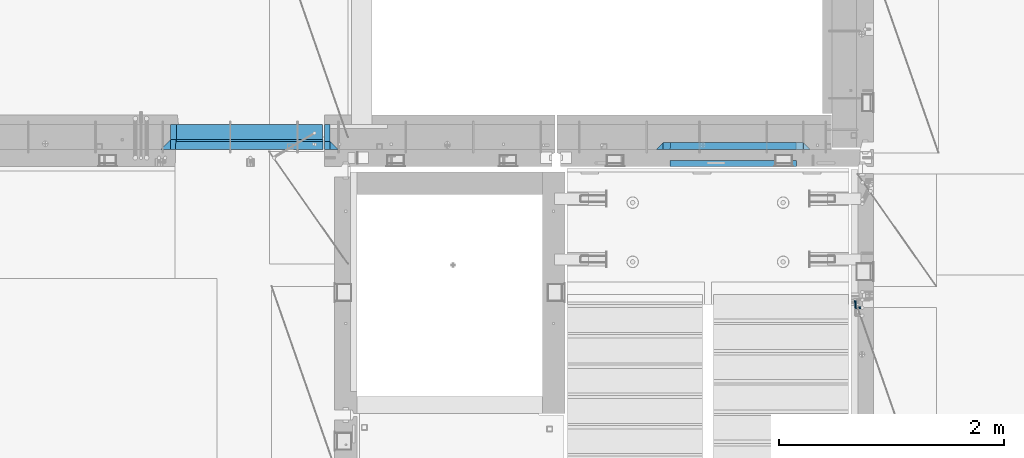
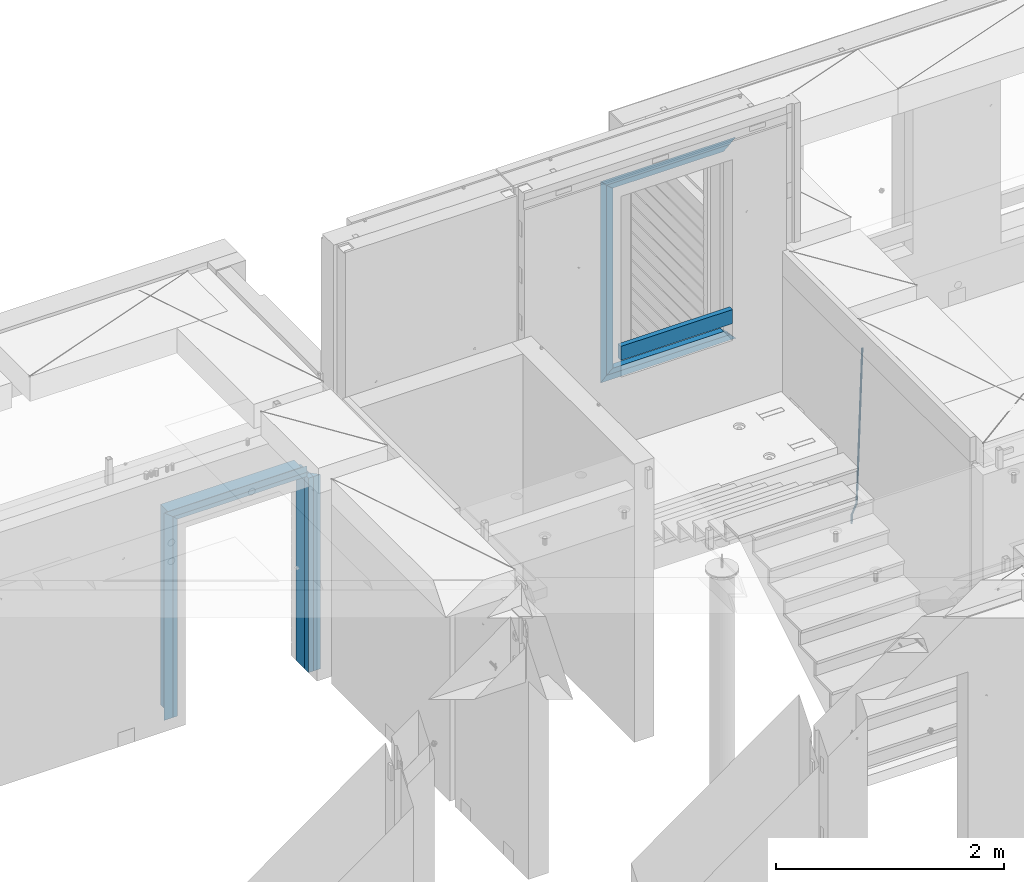
# One storey, part 105 of 325: 17 beams, 4 elements without a shape of their own.
"""IFC2X3 building model written with IfcOpenShell, lengths in millimetres."""

import ifcopenshell
import ifcopenshell.guid

model = None  # the IFC model being written
_history = None  # IfcOwnerHistory: only IFC2X3 demands one
_inside = {}  # id of a spatial element -> (the spatial element, [elements in it])
_under = {}  # id of a project, library or spatial element -> (it, [spatial elements below it])
_declared = {}  # id of a project -> (the project, [libraries it declares])
_typed = {}  # id of a type object -> (the type object, [elements of that type])
_made_of = {}  # id of a material, layer set ... -> (it, [elements and type objects made of it])


def new_model(schema):
    """Start an empty IFC model of exactly this schema.

    Asked for "IFC4X3", IfcOpenShell would pick the latest addendum, in which some entities
    have other attributes; the version numbers below select the first issue.
    IFC2X3 requires an IfcOwnerHistory on every rooted entity: one is made here for all.
    """
    global model, _history
    if schema == "IFC4X3":
        model = ifcopenshell.file(schema_version=(4, 3, 0, 0))
    else:
        model = ifcopenshell.file(schema=schema)
    _inside.clear()
    _under.clear()
    _declared.clear()
    _typed.clear()
    _made_of.clear()
    _history = None
    if model.schema == "IFC2X3":
        org = make("IfcOrganization", Name="unknown")
        user = make(
            "IfcPersonAndOrganization",
            ThePerson=make("IfcPerson", FamilyName="unknown"),
            TheOrganization=org,
        )
        app = make(
            "IfcApplication",
            ApplicationDeveloper=org,
            Version="unknown",
            ApplicationFullName="unknown",
            ApplicationIdentifier="unknown",
        )
        _history = make(
            "IfcOwnerHistory",
            OwningUser=user,
            OwningApplication=app,
            ChangeAction="ADDED",
            CreationDate=0,
        )
    return model


def make(cls, **values):
    """One entity of the class cls with the attributes given. An attribute that is None is left unset."""
    return model.create_entity(
        cls, **{name: value for name, value in values.items() if value is not None}
    )


def rooted(cls, **values):
    """An entity with a GlobalId (a new one), such as an element, a storey or a relation."""
    return make(cls, GlobalId=ifcopenshell.guid.new(), OwnerHistory=_history, **values)


def si_unit(unit_type, name, prefix=None):
    """IfcSIUnit, for example si_unit("LENGTHUNIT", "METRE", prefix="MILLI")."""
    return make("IfcSIUnit", UnitType=unit_type, Prefix=prefix, Name=name)


def assignment(units):
    """IfcUnitAssignment: the units of a project."""
    return None if units is None else make("IfcUnitAssignment", Units=units)


def point(xyz):
    """IfcCartesianPoint."""
    return None if xyz is None else make("IfcCartesianPoint", Coordinates=xyz)


def direction(xyz):
    """IfcDirection."""
    return None if xyz is None else make("IfcDirection", DirectionRatios=xyz)


def frame(location, z_axis=None, x_axis=None):
    """IfcAxis2Placement3D, a coordinate frame: its origin and axes. An axis left out is left unset."""
    return make(
        "IfcAxis2Placement3D",
        Location=point(location),
        Axis=direction(z_axis),
        RefDirection=direction(x_axis),
    )


def origin_with_axes():
    """The frame at (0, 0, 0) with the z axis (0, 0, 1) and the x axis (1, 0, 0) written out."""
    return frame((0.0, 0.0, 0.0), z_axis=(0.0, 0.0, 1.0), x_axis=(1.0, 0.0, 0.0))


def place(relative_to, where):
    """IfcLocalPlacement: puts the frame where relative to a parent placement (None: the world)."""
    return make(
        "IfcLocalPlacement", PlacementRelTo=relative_to, RelativePlacement=where
    )


def context(
    kind, dimensions, precision=None, world=None, true_north=None, identifier=None
):
    """IfcGeometricRepresentationContext, for example the 3D "Model" context."""
    return make(
        "IfcGeometricRepresentationContext",
        ContextIdentifier=identifier,
        ContextType=kind,
        CoordinateSpaceDimension=dimensions,
        Precision=precision,
        WorldCoordinateSystem=world,
        TrueNorth=true_north,
    )


def subcontext(parent, identifier, kind, view, scale=None):
    """IfcGeometricRepresentationSubContext, for example "Body" below "Model"."""
    return make(
        "IfcGeometricRepresentationSubContext",
        ContextIdentifier=identifier,
        ContextType=kind,
        ParentContext=parent,
        TargetScale=scale,
        TargetView=view,
    )


def project(units=None, contexts=None):
    """IfcProject with its units and contexts."""
    return rooted(
        "IfcProject",
        Name="project",
        RepresentationContexts=contexts,
        UnitsInContext=assignment(units),
    )


def spatial(cls, under=None, at=None, **own):
    """A site, building, storey or space (cls), placed at a placement, below another one or the project."""
    s = rooted(cls, ObjectPlacement=at, **own)
    if under is not None:
        _under.setdefault(under.id(), (under, []))[1].append(s)
    return s


def faces_of(points, faces, orient=None, outer=None):
    """IfcFace entities. A face is a list of loops; a loop is a list of indices into points, from 0.

    orient and outer hold one flag for each loop. By default every Orientation is true, the
    first loop of a face is its IfcFaceOuterBound and the others are IfcFaceBound.
    """
    made = []
    for i, loops in enumerate(faces):
        bounds = []
        for j, loop in enumerate(loops):
            is_outer = j == 0 if outer is None else outer[i][j]
            bounds.append(
                make(
                    "IfcFaceOuterBound" if is_outer else "IfcFaceBound",
                    Bound=make("IfcPolyLoop", Polygon=[points[k] for k in loop]),
                    Orientation=True if orient is None else orient[i][j],
                )
            )
        made.append(make("IfcFace", Bounds=bounds))
    return made


def faceted_brep(points, faces, orient=None, outer=None, voids=None):
    """IfcFacetedBrep: a solid bounded by flat faces; with voids (closed shells), ...WithVoids."""
    shared = [point(p) for p in points]
    hull = make("IfcClosedShell", CfsFaces=faces_of(shared, faces, orient, outer))
    if voids is None:
        return make("IfcFacetedBrep", Outer=hull)
    return make(
        "IfcFacetedBrepWithVoids",
        Outer=hull,
        Voids=[
            make(cls, CfsFaces=faces_of(shared, fs, o, b)) for cls, fs, o, b in voids
        ],
    )


def shape(context_of_items, identifier, shape_type, items):
    """IfcShapeRepresentation: the items that make up one representation, for example the "Body"."""
    return make(
        "IfcShapeRepresentation",
        ContextOfItems=context_of_items,
        RepresentationIdentifier=identifier,
        RepresentationType=shape_type,
        Items=items,
    )


def material(Name=None, Category=None):
    """IfcMaterial."""
    return make("IfcMaterial", Name=Name, Category=Category)


def made_of(thing, what):
    """Note that an element or type object is made of a material, layer set ...; save() writes the relation."""
    if what is not None:
        _made_of.setdefault(what.id(), (what, []))[1].append(thing)
    return thing


def type_object(cls, material=None, **own):
    """A type object (cls), such as IfcWallType, which elements share."""
    return made_of(rooted(cls, **own), material)


def element(
    cls,
    number,
    at=None,
    inside=None,
    cuts=None,
    type_object=None,
    material=None,
    context=None,
    identifier="Body",
    shape_type=None,
    held_by="IfcProductDefinitionShape",
    body=None,
    shapes=None,
    **own,
):
    """One element of the class cls, such as IfcWall. Its Tag is "e" and its number.

    at: its placement. inside: the storey or other place that contains it. cuts: it is an
    opening in that element (IfcRelVoidsElement). A single representation is given by context,
    identifier, shape_type and body (its items); several are given by shapes. held_by: the class
    of the entity that holds the representations. save() writes the other relations.
    """
    e = rooted(cls, Tag="e%d" % number, ObjectPlacement=at, **own)
    if body is not None:
        shapes = [shape(context, identifier, shape_type, body)]
    if shapes is not None:
        e.Representation = make(held_by, Representations=shapes)
    if inside is not None:
        _inside.setdefault(inside.id(), (inside, []))[1].append(e)
    if cuts is not None:
        rooted(
            "IfcRelVoidsElement", RelatingBuildingElement=cuts, RelatedOpeningElement=e
        )
    if type_object is not None:
        _typed.setdefault(type_object.id(), (type_object, []))[1].append(e)
    return made_of(e, material)


def aggregate(whole, parts):
    """IfcRelAggregates: a whole, such as a stair, and the parts it consists of."""
    return rooted("IfcRelAggregates", RelatingObject=whole, RelatedObjects=parts)


def save(model, path):
    """Write the relations noted so far, then the file.

    IfcRelAggregates (storeys below a building ...), IfcRelContainedInSpatialStructure (elements
    in a storey), IfcRelDefinesByType, IfcRelAssociatesMaterial and IfcRelDeclares: one each for
    every whole, place, type object, material and project.
    """
    for whole, parts in _under.values():
        aggregate(whole, parts)
    for where, things in _inside.values():
        rooted(
            "IfcRelContainedInSpatialStructure",
            RelatedElements=things,
            RelatingStructure=where,
        )
    for kind, things in _typed.values():
        rooted("IfcRelDefinesByType", RelatedObjects=things, RelatingType=kind)
    for what, things in _made_of.values():
        rooted("IfcRelAssociatesMaterial", RelatedObjects=things, RelatingMaterial=what)
    for by, libraries in _declared.values():
        rooted("IfcRelDeclares", RelatingContext=by, RelatedDefinitions=libraries)
    model.write(path)


model = new_model("IFC2X3")

# Units and contexts
model_context = context("Model", 3, precision=1e-05, world=origin_with_axes())
body_context = subcontext(model_context, "Body", "Model", "MODEL_VIEW")
ifc_project = project(units=[si_unit("LENGTHUNIT", "METRE", prefix="MILLI"), si_unit("AREAUNIT", "SQUARE_METRE"), si_unit("VOLUMEUNIT", "CUBIC_METRE"), si_unit("MASSUNIT", "GRAM", prefix="KILO"), si_unit("TIMEUNIT", "SECOND"), si_unit("PLANEANGLEUNIT", "RADIAN"), si_unit("SOLIDANGLEUNIT", "STERADIAN"), si_unit("THERMODYNAMICTEMPERATUREUNIT", "DEGREE_CELSIUS"), si_unit("LUMINOUSINTENSITYUNIT", "LUMEN")], contexts=[model_context])

# Site, building, storey
site_placement = place(None, origin_with_axes())
site = spatial("IfcSite", under=ifc_project, at=site_placement, CompositionType="ELEMENT")
building_placement = place(site_placement, origin_with_axes())
building = spatial("IfcBuilding", under=site, at=building_placement, CompositionType="ELEMENT")
storey_placement = place(building_placement, origin_with_axes())
storey = spatial("IfcBuildingStorey", under=building, at=storey_placement, Name="1", CompositionType="ELEMENT", Elevation=0.0)

# Assembly, beams
assembly_1_placement = place(storey_placement, origin_with_axes())
assembly_1 = element("IfcElementAssembly", 1, at=assembly_1_placement, inside=storey, AssemblyPlace="NOTDEFINED", PredefinedType="REINFORCEMENT_UNIT")
ifc_material_1 = material(Name="CONCRETE/C25/30")
beam_type_1 = type_object("IfcBeamType", PredefinedType="NOTDEFINED")
beam_1_placement = place(assembly_1_placement, frame((17604.9997605339, 20614.9951872276, 83836.15), z_axis=(1.0, 0.0, 0.0), x_axis=(0.0, 0.0, -1.0)))
beam_1 = element("IfcBeam", 2, at=beam_1_placement, type_object=beam_type_1, material=ifc_material_1, context=body_context, shape_type="Brep", body=[
    faceted_brep([(0.0, -35.0, -35.0), (0.0, -35.0, 35.0), (0.0, 35.0, -35.0), (2081.15000000001, -35.0, -35.0), (2081.15000000001, 35.0, -35.0), (2081.15000000001, -35.0, 35.0)], [[[0, 1, 2]], [[3, 0, 2, 4]], [[3, 4, 5]], [[0, 3, 5, 1]], [[4, 2, 1, 5]]]),
])
beam_type_2 = type_object("IfcBeamType", PredefinedType="NOTDEFINED")
beam_2_placement = place(assembly_1_placement, frame((17544.9997605339, 20614.9951872276, 83836.15), z_axis=(1.0, 0.0, 0.0), x_axis=(0.0, 0.0, -1.0)))
beam_2 = element("IfcBeam", 3, at=beam_2_placement, type_object=beam_type_2, material=ifc_material_1, context=body_context, shape_type="Brep", body=[
    faceted_brep([(0.0, 35.0, -25.0), (0.0, 35.0, 25.0), (2081.14999999999, 35.0, 25.0), (2081.14999999999, 35.0, -25.0), (0.0, -35.0, 25.0), (2081.14999999999, -35.0, 25.0), (0.0, -35.0, -25.0), (2081.14999999999, -35.0, -25.0)], [[[0, 1, 2, 3]], [[1, 4, 5, 2]], [[4, 6, 7, 5]], [[6, 0, 3, 7]], [[5, 7, 3, 2]], [[6, 4, 1, 0]]]),
])

# Assembly, beam
assembly_2_placement = place(storey_placement, origin_with_axes())
assembly_2 = element("IfcElementAssembly", 4, at=assembly_2_placement, inside=storey, AssemblyPlace="NOTDEFINED", PredefinedType="REINFORCEMENT_UNIT")
beam_3_placement = place(assembly_2_placement, frame((17505.0003327385, 20614.9951872276, 83880.0), z_axis=(0.0, 0.0, -1.0), x_axis=(-1.0, 3.00000001838171e-08, 0.0)))
beam_3 = element("IfcBeam", 5, at=beam_3_placement, type_object=beam_type_2, material=ifc_material_1, context=body_context, shape_type="Brep", body=[
    faceted_brep([(0.0, 35.0, -25.0), (0.0, -35.0, -25.0), (0.0, -35.0, 18.8461538461561), (0.0, 35.0, 20.6410256410309), (1309.35954656357, 35.0, 20.6410256410309), (1355.00057220459, 35.0, -25.0), (1355.00057220459, -35.0, -25.0), (1311.15441835844, -35.0, 18.8461538461561)], [[[0, 1, 2, 3]], [[0, 3, 4, 5]], [[1, 0, 5, 6]], [[2, 1, 6, 7]], [[3, 2, 7, 4]], [[6, 5, 4, 7]]]),
])

# Beam
ifc_material_2 = material(Name="TIMBER")
beam_type_3 = type_object("IfcBeamType", Name="50X150", PredefinedType="NOTDEFINED")
beam_4_placement = place(assembly_1_placement, frame((17544.9997605339, 20724.9951872276, 83836.15), z_axis=(1.0, 0.0, 0.0), x_axis=(0.0, 0.0, -1.0)))
beam_4 = element("IfcBeam", 6, at=beam_4_placement, type_object=beam_type_3, material=ifc_material_2, ObjectType="50X150", context=body_context, shape_type="Brep", body=[
    faceted_brep([(0.0, 75.0, -25.0), (1.81898940354586e-12, 75.0, 25.0), (2081.14999999999, 75.0, 25.0), (2081.14999999999, 75.0, -25.0), (1.81898940354586e-12, -75.0000000000009, 25.0), (2081.14999999999, -75.0, 25.0), (0.0, -75.0, -25.0), (2081.14999999999, -75.0, -25.0)], [[[0, 1, 2, 3]], [[1, 4, 5, 2]], [[4, 6, 7, 5]], [[6, 0, 3, 7]], [[5, 7, 3, 2]], [[6, 4, 1, 0]]]),
])

aggregate(assembly_1, [beam_2, beam_1, beam_4])

beam_5_placement = place(assembly_2_placement, frame((17500.0003327385, 20724.9951872276, 83880.0), z_axis=(0.0, 0.0, -1.0), x_axis=(-1.0, 3.00000001838171e-08, 0.0)))
beam_5 = element("IfcBeam", 7, at=beam_5_placement, type_object=beam_type_3, material=ifc_material_2, ObjectType="50X150", context=body_context, shape_type="Brep", body=[
    faceted_brep([(0.0, -75.0, -25.0), (1.81898940354586e-12, -75.0000000000009, 25.0), (1.81898940354586e-12, 75.0, 25.0), (0.0, 75.0, -25.0), (1300.00057220459, 75.0, 25.0), (1350.00057220459, 75.0, -25.0), (1350.00057220459, -75.0, -25.0), (1300.00057220459, -75.0, 25.0)], [[[0, 1, 2, 3]], [[3, 2, 4, 5]], [[0, 3, 5, 6]], [[1, 0, 6, 7]], [[2, 1, 7, 4]], [[6, 5, 4, 7]]]),
])

beam_6_placement = place(assembly_2_placement, frame((16174.9997605339, 20724.9951872276, 83905.0), z_axis=(1.0, 0.0, 0.0), x_axis=(0.0, 0.0, -1.0)))
beam_6 = element("IfcBeam", 8, at=beam_6_placement, type_object=beam_type_3, material=ifc_material_2, ObjectType="50X150", context=body_context, shape_type="Brep", body=[
    faceted_brep([(2145.0, -75.0, 25.0), (2145.0, -75.0, -25.0), (2145.0, 75.0, -25.0), (2145.0, 75.0, 25.0), (50.0000000000036, 75.0, 25.0), (50.0000000000036, -75.0, 25.0), (0.0, -75.0, -25.0), (0.0, 75.0, -25.0)], [[[0, 1, 2, 3]], [[0, 3, 4, 5]], [[1, 0, 5, 6]], [[2, 1, 6, 7]], [[3, 2, 7, 4]], [[5, 4, 7, 6]]]),
])

# Assembly, beam
assembly_3_placement = place(storey_placement, origin_with_axes())
assembly_3 = element("IfcElementAssembly", 9, at=assembly_3_placement, inside=storey, AssemblyPlace="NOTDEFINED", PredefinedType="REINFORCEMENT_UNIT")
ifc_material_3 = material()
beam_type_4 = type_object("IfcBeamType", Name="D20", PredefinedType="NOTDEFINED")
beam_7_placement = place(assembly_3_placement, frame((22244.9999977209, 19244.9999999961, 82510.0), z_axis=(0.999839490204639, 0.000205763000043867, -0.0179151190036643), x_axis=(0.0179151190067552, -2.89999975377855e-08, 0.999839511377188)))
beam_7 = element("IfcBeam", 10, at=beam_7_placement, type_object=beam_type_4, material=ifc_material_3, Name="JM20", ObjectType="D20", context=body_context, shape_type="Brep", body=[
    faceted_brep([(0.0, -10.0, 0.0), (-4.19531716033816e-08, -7.07106781186667, -7.07106781187031), (88.3300330913044, -7.07106781075345, -7.07106781091716), (88.3300330939674, -9.99999999888678, 9.45874489843845e-10), (0.0, 0.0, -10.0), (88.3300330901257, 1.11322151497006e-09, -9.99999999905413), (4.196772351861e-08, 7.07106781186303, -7.07106781186667), (88.3300330911297, 7.07106781297989, -7.07106781092079), (0.0, 10.0, 0.0), (88.33003309372, 10.0000000011132, 9.49512468650937e-10), (4.196772351861e-08, 7.07106781185939, 7.07106781185939), (88.330033096383, 7.07106781297989, 7.07106781281254), (0.0, 0.0, 10.0), (88.3300330975617, 1.11685949377716e-09, 10.0000000009459), (-4.19531716033816e-08, -7.07106781187031, 7.07106781185939), (88.330033096543, -7.07106781075345, 7.07106781281618), (92.5410531336383, -7.07106781069888, -7.07106781086986), (93.1391733354976, -9.99999999882493, 1.00044417195022e-09), (91.031185678381, 1.14596332423389e-09, -9.99999999902502), (89.4940308476071, 7.07106781299808, -7.0710678109026), (88.8300330937054, 10.0000000011205, 9.53150447458029e-10), (89.4281532955793, 7.07106781299444, 7.07106781282346), (90.9380207508511, 1.1423253454268e-09, 10.000000000975), (92.4751755816251, -7.07106781070252, 7.0710678128562), (96.3782848142582, -5.33701554197978, -7.03357706842144), (97.521433478134, -8.01964833519742, 0.0428158119902946), (93.4925722739135, 1.1123052684452, -9.97595161763456), (90.5547071261244, 7.55038943342879, -7.06070473030923), (89.2856509300182, 10.2058945648241, 0.00445150463565369), (90.4287995938939, 7.52326177160285, 7.08084438504739), (93.3145121342386, 1.07394096118151, 10.0232189342605), (96.2523772820277, -5.36414320380209, 7.1079720469279), (257.506815959452, 67.4772730503937, -5.45930979303739), (258.649964623342, 64.7946402571761, 1.6170830873707), (254.621103419107, 73.9265938608187, -8.40168434225416), (251.683238271318, 80.3646780258023, -5.48643745492518), (250.414182075212, 83.020183157194, 1.57871878001606), (251.557330739088, 80.33755036398, 8.65511166042415), (254.443043279447, 73.8882295535514, 11.5974862096446), (257.380908427236, 67.4501453885678, 8.68223932231558), (258.602930279812, 67.972609189088, -5.44860047364273), (259.105582459641, 65.0005348208797, 1.62153459105684), (257.132348490195, 75.0614302677059, -8.37714883071021), (255.555283958587, 82.1144628101138, -5.44860657065874), (254.795559698876, 85.0001360088281, 1.6215259685705), (255.298211878704, 82.0280616406199, 8.69166103325915), (256.768793668292, 74.9392405620019, 11.6202093903339), (258.345858199915, 67.8862080195941, 8.6916671302788), (259.805334557794, 67.9726163208943, -5.41449570430632), (259.605381454428, 65.000537785334, 1.63571079596295), (259.887108427691, 75.0614466069856, -8.29901333673115), (259.802801040176, 82.1144880033607, -5.32813079313928), (259.601798519448, 85.0001645160155, 1.75784922465755), (259.401845416098, 82.0280859804552, 8.80805572493045), (259.320071546215, 74.939255694364, 11.6925733573553), (259.404378933716, 67.8862142979851, 8.72169081375614), (379.556031234519, 67.9733265968243, -2.01790941325453), (379.356078131153, 65.0012480612531, 5.03229708701838), (379.637805104416, 75.0621568829047, -4.90242704567936), (379.553497716901, 82.1151982792871, -1.93154450208385), (379.352495196188, 85.0008747919419, 5.15443551570934), (379.152542092823, 82.028796256378, 12.2046420159822), (379.07076822294, 74.9399659702904, 15.0891596484107), (379.155075610441, 67.8869245739115, 12.1182771048116), (380.072762519878, 67.9733296617014, -2.00325294403592), (379.914212471936, 65.001251371712, 5.04812790473807), (380.137604099218, 75.062159847359, -4.88825084076962), (380.070753892185, 82.115201347282, -1.91687314497904), (379.911371843409, 85.0008781067991, 5.17028738806766), (379.752821795468, 82.0287998168096, 12.2216682368417), (379.687980216127, 74.9399696311521, 15.1066661335717), (379.75483042316, 67.8869281312291, 12.1352884377848), (380.589630311282, 67.9733314360055, -1.99466693466456), (380.47249425629, 65.0012532881774, 5.05740186745606), (380.63753512704, 75.0621615635209, -4.87994617841832), (380.588146712194, 82.1152031233905, -1.90827841404098), (380.470396130346, 85.0008800258147, 5.17957368496354), (380.353260075353, 82.0288018779938, 12.2316424870805), (380.305355259596, 74.9399717504712, 15.1169217308343), (380.354743674427, 67.8869301906088, 12.1452539664606), (1774.34427586624, 67.9781159117483, 21.1578502885204), (1774.22713981124, 65.0060377639238, 28.2099190906447), (1774.392180682, 75.0669460392637, 18.2725710447667), (1774.34279226715, 82.1199875991297, 21.2442388091476), (1774.22504168531, 85.0056645015611, 28.3320909081413), (1774.10790563031, 82.0335863537366, 35.3841597102692), (1774.06000081454, 74.9447562262212, 38.2694389540193), (1774.10938922939, 67.8917146663516, 35.2977711896456), (1774.88372517048, 67.9781177635668, 21.1668114133099), (1774.72778509965, 65.0060394825341, 28.2182356180165), (1774.98579289111, 75.0669480770157, 18.2824319029423), (1774.97419837512, 82.1199897666229, 21.2547274850658), (1774.85573353268, 85.0056666665987, 28.3425677190426), (1774.69979346184, 82.033588385566, 35.3939919237528), (1774.5977257412, 74.9447580721171, 38.2783714341131), (1774.60932025722, 67.8917163825099, 35.3060758519969), (1775.42307107328, 67.9710843860266, 21.1787438207648), (1775.22833442455, 64.9995120344502, 28.229309695831), (1775.57929131688, 75.0592085197495, 18.2955623726557), (1775.60548345537, 82.1117574498749, 21.2686939410269), (1775.48630448926, 84.9974436624325, 28.3565183758365), (1775.29156784054, 82.025871310856, 35.4070842509027), (1775.13534759694, 74.9377471771331, 38.2902656990118), (1775.10915545844, 67.8851982470042, 35.3171341306479), (1797.26037838872, 67.6863134698579, 21.6618691162184), (1797.06564173999, 64.7147411182814, 28.7124349912847), (1797.41659863231, 74.774437603588, 18.778687668113), (1797.4427907708, 81.8269865337097, 21.7518192364769), (1797.32361180469, 84.7126727462673, 28.8396436712901), (1797.12887515598, 81.7411003946909, 35.89020954636), (1796.97265491237, 74.6529762609607, 38.7733909944654), (1796.94646277388, 67.600427330839, 35.8002594261015), (1797.89535440278, 67.678033021235, 21.6759172298407), (1797.72560625478, 64.7061348053903, 28.7270359467329), (1797.99432328039, 74.7669037453634, 18.7914691611404), (1797.96453826137, 81.8201826494806, 21.7633622993126), (1797.82344700591, 84.7061546107579, 28.8507019499411), (1797.65369885792, 81.7342563949169, 35.9018206668334), (1797.55472998031, 74.6453856707885, 38.7862687355337), (1797.58451499933, 67.5921067666677, 35.8143755973615), (1798.53038580362, 67.6799033488787, 21.6897764077366), (1798.38562805518, 64.7081042942737, 28.7414499208317), (1798.5720988481, 74.7685931450651, 18.8040562622737), (1798.48633225287, 81.8217153396909, 21.7747052084378), (1798.32332692624, 84.7076466082108, 28.861557382621), (1798.17856917779, 81.7358475536093, 35.9132308957123), (1798.13685613332, 74.6471577574157, 38.7989510411717), (1798.22262272854, 67.5940355627936, 35.8283020950112), (1898.53586621479, 67.9783489823094, 23.8684775158254), (1898.39110846636, 65.006549927708, 30.9201510289131), (1898.57757925926, 75.0670387784958, 20.9827573703624), (1898.49181266406, 82.1201609731179, 23.9534063165302), (1898.3288073374, 85.0060922416415, 31.0402584907024), (1898.18404958898, 82.0342931870364, 38.0919320037974), (1898.14233654451, 74.9456033908464, 40.9776521492568), (1898.22810313971, 67.8924811962243, 38.0070032030926)], [[[0, 1, 2, 3]], [[1, 4, 5, 2]], [[4, 6, 7, 5]], [[6, 8, 9, 7]], [[8, 10, 11, 9]], [[10, 12, 13, 11]], [[12, 14, 15, 13]], [[14, 0, 3, 15]], [[14, 12, 10, 8, 6, 4, 1, 0]], [[3, 2, 16, 17]], [[2, 5, 18, 16]], [[5, 7, 19, 18]], [[7, 9, 20, 19]], [[9, 11, 21, 20]], [[11, 13, 22, 21]], [[13, 15, 23, 22]], [[15, 3, 17, 23]], [[17, 16, 24, 25]], [[16, 18, 26, 24]], [[18, 19, 27, 26]], [[19, 20, 28, 27]], [[20, 21, 29, 28]], [[21, 22, 30, 29]], [[22, 23, 31, 30]], [[23, 17, 25, 31]], [[25, 24, 32, 33]], [[24, 26, 34, 32]], [[26, 27, 35, 34]], [[27, 28, 36, 35]], [[28, 29, 37, 36]], [[29, 30, 38, 37]], [[30, 31, 39, 38]], [[31, 25, 33, 39]], [[33, 32, 40, 41]], [[32, 34, 42, 40]], [[34, 35, 43, 42]], [[35, 36, 44, 43]], [[36, 37, 45, 44]], [[37, 38, 46, 45]], [[38, 39, 47, 46]], [[39, 33, 41, 47]], [[41, 40, 48, 49]], [[40, 42, 50, 48]], [[42, 43, 51, 50]], [[43, 44, 52, 51]], [[44, 45, 53, 52]], [[45, 46, 54, 53]], [[46, 47, 55, 54]], [[47, 41, 49, 55]], [[49, 48, 56, 57]], [[48, 50, 58, 56]], [[50, 51, 59, 58]], [[51, 52, 60, 59]], [[52, 53, 61, 60]], [[53, 54, 62, 61]], [[54, 55, 63, 62]], [[55, 49, 57, 63]], [[57, 56, 64, 65]], [[56, 58, 66, 64]], [[58, 59, 67, 66]], [[59, 60, 68, 67]], [[60, 61, 69, 68]], [[61, 62, 70, 69]], [[62, 63, 71, 70]], [[63, 57, 65, 71]], [[65, 64, 72, 73]], [[64, 66, 74, 72]], [[66, 67, 75, 74]], [[67, 68, 76, 75]], [[68, 69, 77, 76]], [[69, 70, 78, 77]], [[70, 71, 79, 78]], [[71, 65, 73, 79]], [[73, 72, 80, 81]], [[72, 74, 82, 80]], [[74, 75, 83, 82]], [[75, 76, 84, 83]], [[76, 77, 85, 84]], [[77, 78, 86, 85]], [[78, 79, 87, 86]], [[79, 73, 81, 87]], [[81, 80, 88, 89]], [[80, 82, 90, 88]], [[82, 83, 91, 90]], [[83, 84, 92, 91]], [[84, 85, 93, 92]], [[85, 86, 94, 93]], [[86, 87, 95, 94]], [[87, 81, 89, 95]], [[89, 88, 96, 97]], [[88, 90, 98, 96]], [[90, 91, 99, 98]], [[91, 92, 100, 99]], [[92, 93, 101, 100]], [[93, 94, 102, 101]], [[94, 95, 103, 102]], [[95, 89, 97, 103]], [[97, 96, 104, 105]], [[96, 98, 106, 104]], [[98, 99, 107, 106]], [[99, 100, 108, 107]], [[100, 101, 109, 108]], [[101, 102, 110, 109]], [[102, 103, 111, 110]], [[103, 97, 105, 111]], [[105, 104, 112, 113]], [[104, 106, 114, 112]], [[106, 107, 115, 114]], [[107, 108, 116, 115]], [[108, 109, 117, 116]], [[109, 110, 118, 117]], [[110, 111, 119, 118]], [[111, 105, 113, 119]], [[113, 112, 120, 121]], [[112, 114, 122, 120]], [[114, 115, 123, 122]], [[115, 116, 124, 123]], [[116, 117, 125, 124]], [[117, 118, 126, 125]], [[118, 119, 127, 126]], [[119, 113, 121, 127]], [[121, 120, 128, 129]], [[120, 122, 130, 128]], [[122, 123, 131, 130]], [[123, 124, 132, 131]], [[124, 125, 133, 132]], [[125, 126, 134, 133]], [[126, 127, 135, 134]], [[127, 121, 129, 135]], [[130, 131, 132, 133, 134, 135, 129, 128]]]),
])
aggregate(assembly_3, [beam_7])

# Assembly, beams
assembly_4_placement = place(storey_placement, origin_with_axes())
assembly_4 = element("IfcElementAssembly", 11, at=assembly_4_placement, inside=storey, AssemblyPlace="NOTDEFINED", PredefinedType="REINFORCEMENT_UNIT")
ifc_material_4 = material(Name="TIMBER/T24")
beam_type_5 = type_object("IfcBeamType", PredefinedType="NOTDEFINED")
beam_8_placement = place(assembly_4_placement, frame((21724.9984049797, 20455.0, 84185.0), z_axis=(0.0, 0.0, 1.0), x_axis=(-1.0, 3.00000001838171e-08, 0.0)))
beam_8 = element("IfcBeam", 12, at=beam_8_placement, type_object=beam_type_5, material=ifc_material_4, context=body_context, shape_type="Brep", body=[
    faceted_brep([(-3.63797880709171e-12, 24.9999999999964, -75.0), (-3.63797880709171e-12, 24.9999999999964, 75.0), (1130.0, 25.0, 75.0), (1130.0, 25.0, -75.0), (0.0, -25.0000000000073, 75.0), (1130.0, -25.0, 75.0), (0.0, -25.0000000000073, -75.0), (1130.0, -25.0, -75.0)], [[[0, 1, 2, 3]], [[1, 4, 5, 2]], [[4, 6, 7, 5]], [[6, 0, 3, 7]], [[5, 7, 3, 2]], [[6, 4, 1, 0]]]),
])
beam_type_6 = type_object("IfcBeamType", PredefinedType="NOTDEFINED")
beam_9_placement = place(assembly_4_placement, frame((21784.999845922, 20609.9999988829, 85885.0), z_axis=(0.0, 0.0, -1.0), x_axis=(-1.0, 3.00000001838171e-08, 0.0)))
beam_9 = element("IfcBeam", 13, at=beam_9_placement, type_object=beam_type_6, material=ifc_material_1, context=body_context, shape_type="Brep", body=[
    faceted_brep([(64.0544355865859, -29.9999988381387, 24.9038019193104), (65.6760571454033, 29.9999988381387, 26.2937632551475), (0.0, 30.0, -30.0), (0.0, -30.0, -30.0), (64.0544355865859, -29.9999988381387, 24.0540541168593), (65.6760571454033, 29.9999988381387, 25.6756756756804), (1185.94632735287, -29.9999988381387, 24.0540541168593), (1184.32470579405, 29.9999988381387, 25.6756756756804), (1184.32470579405, 29.9999988381387, 26.2934362810629), (1250.00038146973, 29.9999988381387, -30.0), (1250.00038146973, -29.9999988381387, -30.0), (1185.94632735287, -29.9999988381387, 24.9034749452549)], [[[0, 1, 2, 3]], [[4, 5, 1, 0]], [[6, 7, 5, 4]], [[2, 1, 5, 7, 8, 9]], [[3, 2, 9, 10]], [[6, 4, 0, 3, 10, 11]], [[7, 6, 11, 8]], [[10, 9, 8, 11]]]),
])
beam_10_placement = place(assembly_4_placement, frame((21844.999845922, 20610.0000000447, 85945.0), z_axis=(0.0, 0.0, -1.0), x_axis=(-1.0, 3.00000001838171e-08, 0.0)))
beam_10 = element("IfcBeam", 14, at=beam_10_placement, type_object=beam_type_6, material=ifc_material_1, context=body_context, shape_type="Brep", body=[
    faceted_brep([(60.0000000000073, 30.0, 30.0), (0.0, -30.0, -30.0), (60.0000000000073, -30.0, 30.0), (1310.0003814697, 30.0, 30.0), (1370.00038146973, -30.0, -30.0), (1310.0003814697, -30.0, 30.0)], [[[0, 1, 2]], [[1, 0, 3, 4]], [[2, 1, 4, 5]], [[0, 2, 5, 3]], [[4, 3, 5]]]),
])
beam_11_placement = place(assembly_4_placement, frame((20504.9994644523, 20610.0000000447, 85975.0), z_axis=(1.0, 0.0, 0.0), x_axis=(0.0, 0.0, -1.0)))
beam_11 = element("IfcBeam", 15, at=beam_11_placement, type_object=beam_type_6, material=ifc_material_1, context=body_context, shape_type="Brep", body=[
    faceted_brep([(60.0000000000073, 30.0, 30.0), (0.0, -30.0, -30.0), (60.0000000000073, -30.0, 30.0), (2155.0, -30.0, -30.0), (2095.00000000001, 30.0, 30.0), (2095.00000000001, -30.0, 30.0)], [[[0, 1, 2]], [[3, 1, 0, 4]], [[5, 2, 1, 3]], [[2, 5, 4, 0]], [[5, 3, 4]]]),
])
beam_12_placement = place(assembly_4_placement, frame((20474.9994644523, 20610.0000000447, 83850.0), z_axis=(0.0, 0.0, 1.0), x_axis=(1.0, 0.0, 0.0)))
beam_12 = element("IfcBeam", 16, at=beam_12_placement, type_object=beam_type_6, material=ifc_material_1, context=body_context, shape_type="Brep", body=[
    faceted_brep([(1370.00038146973, -30.0, -30.0), (1310.0003814697, 30.0, 30.0), (1310.0003814697, -30.0, 30.0), (60.0000000000073, 30.0, 30.0), (60.0000000000073, -30.0, 30.0), (0.0, -30.0, -30.0)], [[[0, 1, 2]], [[3, 4, 2, 1]], [[4, 5, 0, 2]], [[5, 3, 1, 0]], [[3, 5, 4]]]),
])
beam_13_placement = place(assembly_4_placement, frame((20534.9994644523, 20609.9999988829, 83910.0), z_axis=(0.0, 0.0, 1.0), x_axis=(1.0, 0.0, 0.0)))
beam_13 = element("IfcBeam", 17, at=beam_13_placement, type_object=beam_type_6, material=ifc_material_1, context=body_context, shape_type="Brep", body=[
    faceted_brep([(1185.94594588314, -29.9999988381387, 24.9038019193104), (1250.00038146973, -29.9999988381387, -30.0), (1250.00038146973, 29.9999988381387, -30.0), (1184.32432432432, 29.9999988381387, 26.2937632551329), (1184.32432432432, 29.9999988381387, 25.6756756756804), (1185.94594588314, -29.9999988381387, 24.0540541168593), (65.6756756756768, 30.0, 25.6756756756804), (64.0540540540533, -30.0, 24.0540540540533), (65.6756756756768, 30.0, 26.293436281092), (64.0540540540533, -30.0, 24.9034748914419), (0.0, -30.0, -30.0), (0.0, 30.0, -30.0)], [[[0, 1, 2, 3]], [[4, 5, 0, 3]], [[5, 4, 6, 7]], [[7, 6, 8, 9]], [[1, 0, 5, 7, 9, 10]], [[10, 11, 2, 1]], [[6, 4, 3, 2, 11, 8]], [[10, 9, 8, 11]]]),
])
beam_type_7 = type_object("IfcBeamType", PredefinedType="NOTDEFINED")
beam_14_placement = place(assembly_4_placement, frame((20569.9994644523, 20609.9999988829, 85915.0), z_axis=(1.0, 0.0, 0.0), x_axis=(0.0, 0.0, -1.0)))
beam_14 = element("IfcBeam", 18, at=beam_14_placement, type_object=beam_type_7, material=ifc_material_1, context=body_context, shape_type="Brep", body=[
    faceted_brep([(0.0, -30.0, -35.0), (54.9034748914273, -30.0, 29.0540540540533), (56.2934362811066, 30.0, 30.6756756756768), (0.0, 30.0, -35.0), (1978.70656371892, 29.9999988381387, 30.6756756756731), (2035.0, 29.9999988381387, -35.0), (2035.0, -29.9999988381387, -35.0), (1980.09652505475, -29.9999988381387, 29.0540541168557)], [[[0, 1, 2, 3]], [[4, 5, 3, 2]], [[5, 6, 0, 3]], [[6, 7, 1, 0]], [[7, 4, 2, 1]], [[6, 5, 4, 7]]]),
])
aggregate(assembly_4, [beam_9, beam_10, beam_11, beam_14, beam_12, beam_13, beam_8])

# Beam
beam_type_8 = type_object("IfcBeamType", PredefinedType="NOTDEFINED")
beam_15_placement = place(assembly_2_placement, frame((17505.0003327385, 20624.9951872276, 83940.0), z_axis=(0.0, 0.0, -1.0), x_axis=(-1.0, 3.00000001838171e-08, 0.0)))
beam_15 = element("IfcBeam", 19, at=beam_15_placement, type_object=beam_type_8, material=ifc_material_1, context=body_context, shape_type="Brep", body=[
    faceted_brep([(0.0, -45.0, 35.0), (0.0, 45.0, 35.0), (0.0, -45.0, -35.0), (1355.00057231861, 45.0, 35.0), (1445.00057220459, -45.0, -35.0), (1355.00057231861, -45.0, 35.0)], [[[0, 1, 2]], [[2, 1, 3, 4]], [[0, 2, 4, 5]], [[1, 0, 5, 3]], [[4, 3, 5]]]),
])

beam_type_9 = type_object("IfcBeamType", PredefinedType="NOTDEFINED")
beam_16_placement = place(assembly_2_placement, frame((16174.9997605339, 20624.9951872276, 83905.0), z_axis=(1.0, 0.0, 0.0), x_axis=(0.0, 0.0, -1.0)))
beam_16 = element("IfcBeam", 20, at=beam_16_placement, type_object=beam_type_9, material=ifc_material_1, context=body_context, shape_type="Brep", body=[
    faceted_brep([(2150.0, -45.0, -25.0), (2150.0, 45.0, -25.0), (2150.0, 45.0, 21.1538461538439), (2150.0, -45.0, 18.8461538461524), (46.1538461538439, 45.0, 21.1538461538439), (43.8461538461561, -45.0, 18.8461538461524), (0.0, -45.0, -25.0), (0.0, 45.0, -25.0)], [[[0, 1, 2, 3]], [[3, 2, 4, 5]], [[0, 3, 5, 6]], [[1, 0, 6, 7]], [[2, 1, 7, 4]], [[6, 5, 4, 7]]]),
])

beam_type_10 = type_object("IfcBeamType", PredefinedType="NOTDEFINED")
beam_17_placement = place(assembly_2_placement, frame((16104.9997605339, 20624.9951872276, 83975.0), z_axis=(1.0, 0.0, 0.0), x_axis=(0.0, 0.0, -1.0)))
beam_17 = element("IfcBeam", 21, at=beam_17_placement, type_object=beam_type_10, material=ifc_material_1, context=body_context, shape_type="Brep", body=[
    faceted_brep([(70.0000000886939, -45.0, 45.0), (70.0000000886939, 45.0, 45.0), (1.81898940354586e-12, -45.0000000000009, -45.0), (2220.0, -45.0, 45.0), (2220.0, -45.0, -45.0), (2220.0, 45.0, 45.0)], [[[0, 1, 2]], [[3, 0, 2, 4]], [[3, 4, 5]], [[0, 3, 5, 1]], [[4, 2, 1, 5]]]),
])

aggregate(assembly_2, [beam_15, beam_3, beam_16, beam_17, beam_5, beam_6])

save(model, "model.ifc")
